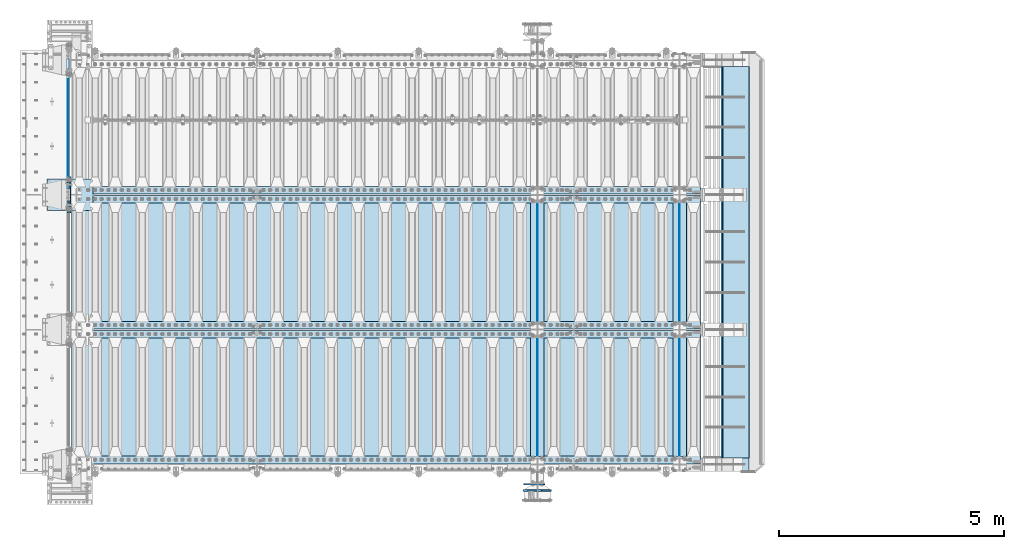
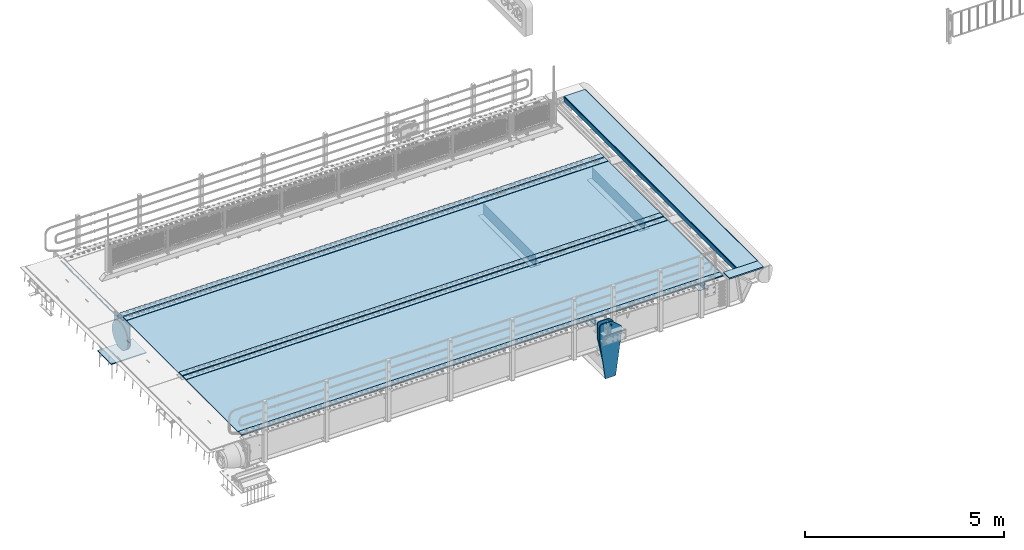
# One storey, part 171 of 219: 24 plates.
"""IFC2X3 building model written with IfcOpenShell, lengths in millimetres."""

from ifc_helpers import new_model, si_unit, frame, origin_with_axes, place, context, subcontext, project, spatial, faceted_brep, material, type_object, element, save


model = new_model("IFC2X3")

# Units and contexts
model_context = context("Model", 3, precision=1e-05, world=origin_with_axes())
body_context = subcontext(model_context, "Body", "Model", "MODEL_VIEW")
ifc_project = project(units=[si_unit("LENGTHUNIT", "METRE", prefix="MILLI"), si_unit("AREAUNIT", "SQUARE_METRE"), si_unit("VOLUMEUNIT", "CUBIC_METRE"), si_unit("MASSUNIT", "GRAM", prefix="KILO"), si_unit("TIMEUNIT", "SECOND"), si_unit("PLANEANGLEUNIT", "RADIAN"), si_unit("SOLIDANGLEUNIT", "STERADIAN"), si_unit("THERMODYNAMICTEMPERATUREUNIT", "DEGREE_CELSIUS"), si_unit("LUMINOUSINTENSITYUNIT", "LUMEN")], contexts=[model_context])

# Site, building, storey
site_placement = place(None, origin_with_axes())
site = spatial("IfcSite", under=ifc_project, at=site_placement, CompositionType="ELEMENT")
building_placement = place(site_placement, origin_with_axes())
building = spatial("IfcBuilding", under=site, at=building_placement, Name="Standard", CompositionType="ELEMENT")
storey_placement = place(building_placement, origin_with_axes())
storey = spatial("IfcBuildingStorey", under=building, at=storey_placement, Name="Undefined", CompositionType="ELEMENT", Elevation=0.0)

# Plates
ifc_material_1 = material(Name="STEEL/S355N")
plate_type_1 = type_object("IfcPlateType", PredefinedType="NOTDEFINED")
plate_1_placement = place(storey_placement, frame((-57.5, 33002.5000993725, -35.9858217417067), z_axis=(0.0, -0.999999999987744, -4.95099999993769e-06), x_axis=(0.0, 4.95100000930963e-06, -0.999999999987744)))
element("IfcPlate", 1, at=plate_1_placement, inside=storey, type_object=plate_type_1, material=ifc_material_1, context=body_context, shape_type="Brep", body=[
    faceted_brep([(0.0, -7.49999999999999, 0.0), (8.68993765834603e-12, -7.49999999999999, 150.000000000004), (8.68993765834603e-12, 7.5, 150.000000000004), (0.0, 7.5, 0.0), (-14.9999999999986, -7.49999999999999, 150.0), (-14.9999999999986, 7.5, 150.0), (-14.9999999999972, -7.49999999999999, 300.0), (-14.9999999999972, 7.5, 300.0), (1.55395696310734e-11, -7.49999999999999, 300.0), (1.55395696310734e-11, 7.5, 300.0), (1.87725390787818e-11, -7.49999999999999, 450.0), (1.87725390787818e-11, 7.5, 450.0), (-14.9999999999958, -7.49999999999999, 450.0), (-14.9999999999958, 7.5, 450.0), (-14.9999999999944, -7.49999999999999, 600.0), (-14.9999999999944, 7.5, 600.0), (2.74553713097703e-11, -7.49999999999999, 600.000000000004), (2.74553713097703e-11, 7.5, 600.000000000004), (3.24931193063094e-11, -7.49999999999999, 750.0), (3.24931193063094e-11, 7.5, 750.0), (-14.999999999993, -7.49999999999999, 750.0), (-14.999999999993, 7.5, 750.0), (-14.9999999999916, -7.49999999999999, 900.000000000004), (-14.9999999999916, 7.5, 900.000000000004), (4.11830569646554e-11, -7.49999999999999, 900.0), (4.11830569646554e-11, 7.5, 900.0), (4.62208049611945e-11, -7.49999999999999, 1050.0), (4.62208049611945e-11, 7.5, 1050.0), (-14.9999999999902, -7.49999999999999, 1050.0), (-14.9999999999902, 7.5, 1050.0), (-14.9999999999888, -7.49999999999999, 1200.0), (-14.9999999999888, 7.5, 1200.0), (5.30917532159947e-11, -7.49999999999999, 1200.0), (5.30917532159947e-11, 7.5, 1200.0), (5.99484906160797e-11, -7.49999999999999, 1350.0), (5.99484906160797e-11, 7.5, 1350.0), (-14.9999999999873, -7.49999999999999, 1350.0), (-14.9999999999873, 7.5, 1350.0), (-14.9999999999859, -7.49999999999999, 1500.0), (-14.9999999999859, 7.5, 1500.0), (6.49933440399764e-11, -7.49999999999999, 1500.0), (6.49933440399764e-11, 7.5, 1500.0), (7.36761762709648e-11, -7.49999999999999, 1650.0), (7.36761762709648e-11, 7.5, 1650.0), (-14.9999999999845, -7.49999999999999, 1650.0), (-14.9999999999845, 7.5, 1650.0), (-14.9999999999831, -7.49999999999999, 1800.0), (-14.9999999999831, 7.5, 1800.0), (7.6894934863958e-11, -7.49999999999999, 1800.0), (7.6894934863958e-11, 7.5, 1800.0), (8.37587776914006e-11, -7.49999999999999, 1950.0), (8.37587776914006e-11, 7.5, 1950.0), (-14.9999999999817, -7.49999999999999, 1950.0), (-14.9999999999817, 7.5, 1950.0), (-14.9999999999803, -7.49999999999999, 2100.0), (-14.9999999999803, 7.5, 2100.0), (9.06297259462008e-11, -7.49999999999999, 2100.0), (9.06297259462008e-11, 7.5, 2100.0), (9.56674739427399e-11, -7.49999999999999, 2250.0), (9.56674739427399e-11, 7.5, 2250.0), (-14.9999999999789, -7.49999999999999, 2250.0), (-14.9999999999789, 7.5, 2250.0), (-14.9999999999775, -7.49999999999999, 2400.0), (-14.9999999999775, 7.5, 2400.0), (1.04350306173728e-10, -7.49999999999999, 2400.0), (1.04350306173728e-10, 7.5, 2400.0), (1.09388054170267e-10, -7.49999999999999, 2550.0), (1.09388054170267e-10, 7.5, 2550.0), (-14.9999999999761, -7.49999999999999, 2550.0), (-14.9999999999761, 7.5, 2550.0), (-14.9999999999747, -7.49999999999999, 2700.0), (-14.9999999999747, 7.5, 2700.0), (1.14440013021522e-10, -7.49999999999999, 2700.0), (1.14440013021522e-10, 7.5, 2700.0), (1.23115739825153e-10, -7.49999999999999, 2850.0), (1.23115739825153e-10, 7.5, 2850.0), (25.0000000000267, -7.49999999999999, 2850.0), (25.0000000000267, 7.5, 2850.0), (25.0, -7.49999999999999, 0.0), (25.0, 7.5, 0.0)], [[[0, 1, 2, 3]], [[1, 4, 5, 2]], [[4, 6, 7, 5]], [[6, 8, 9, 7]], [[8, 10, 11, 9]], [[10, 12, 13, 11]], [[12, 14, 15, 13]], [[14, 16, 17, 15]], [[16, 18, 19, 17]], [[18, 20, 21, 19]], [[20, 22, 23, 21]], [[22, 24, 25, 23]], [[24, 26, 27, 25]], [[26, 28, 29, 27]], [[28, 30, 31, 29]], [[30, 32, 33, 31]], [[32, 34, 35, 33]], [[34, 36, 37, 35]], [[36, 38, 39, 37]], [[38, 40, 41, 39]], [[40, 42, 43, 41]], [[42, 44, 45, 43]], [[44, 46, 47, 45]], [[46, 48, 49, 47]], [[48, 50, 51, 49]], [[50, 52, 53, 51]], [[52, 54, 55, 53]], [[54, 56, 57, 55]], [[56, 58, 59, 57]], [[58, 60, 61, 59]], [[60, 62, 63, 61]], [[62, 64, 65, 63]], [[64, 66, 67, 65]], [[66, 68, 69, 67]], [[68, 70, 71, 69]], [[70, 72, 73, 71]], [[72, 74, 75, 73]], [[74, 76, 77, 75]], [[76, 78, 79, 77]], [[78, 0, 3, 79]], [[5, 7, 9, 11, 13, 15, 17, 19, 21, 23, 25, 27, 29, 31, 33, 35, 37, 39, 41, 43, 45, 47, 49, 51, 53, 55, 57, 59, 61, 63, 65, 67, 69, 71, 73, 75, 77, 79, 3, 2]], [[78, 76, 74, 72, 70, 68, 66, 64, 62, 60, 58, 56, 54, 52, 50, 48, 46, 44, 42, 40, 38, 36, 34, 32, 30, 28, 26, 24, 22, 20, 18, 16, 14, 12, 10, 8, 6, 4, 1, 0]]]),
])
plate_type_2 = type_object("IfcPlateType", PredefinedType="NOTDEFINED")
for number, where, z_axis, x_axis in (
    (2, (13555.0, 26825.0, 0.0), (0.0, 0.0, -1.0), (0.0, -1.0, 0.0)),
    (3, (13555.0, 29825.0, 0.0), (0.0, 0.0, -1.0), (0.0, -1.0, 0.0)),
    (4, (10390.0, 29825.0, 0.0), (0.0, 0.0, -1.0), (0.0, -1.0, 0.0)),
    (5, (10390.0, 26825.0, 0.0), (0.0, 0.0, -1.0), (0.0, -1.0, 0.0)),
):
    element("IfcPlate", number, at=place(storey_placement, frame(where, z_axis=z_axis, x_axis=x_axis)), inside=storey, type_object=plate_type_2, material=ifc_material_1, context=body_context, shape_type="Brep", body=[
        faceted_brep([(0.0, -5.0, 0.0), (0.0, -5.0, 336.0), (0.0, 5.0, 336.0), (0.0, 5.0, 0.0), (2650.0, -5.0, 336.0), (2650.0, 5.0, 336.0), (2650.0, -5.0, 0.0), (2650.0, 5.0, 0.0)], [[[0, 1, 2, 3]], [[1, 4, 5, 2]], [[4, 6, 7, 5]], [[6, 0, 3, 7]], [[5, 7, 3, 2]], [[6, 4, 1, 0]]]),
    ])
plate_type_3 = type_object("IfcPlateType", PredefinedType="NOTDEFINED")
for number, where, z_axis, x_axis in (
    (6, (13405.0, 24175.0, -343.0), (0.0, 1.0, 0.0), (1.0, 0.0, 0.0)),
    (7, (13405.0, 27175.0, -343.0), (0.0, 1.0, 0.0), (1.0, 0.0, 0.0)),
    (8, (10240.0, 27175.0, -343.0), (0.0, 1.0, 0.0), (1.0, 0.0, 0.0)),
    (9, (10240.0, 24175.0, -343.0), (0.0, 1.0, 0.0), (1.0, 0.0, 0.0)),
):
    element("IfcPlate", number, at=place(storey_placement, frame(where, z_axis=z_axis, x_axis=x_axis)), inside=storey, type_object=plate_type_3, material=ifc_material_1, context=body_context, shape_type="Brep", body=[
        faceted_brep([(0.0, -7.0, 0.0), (0.0, -7.0, 2650.0), (0.0, 7.0, 2650.0), (0.0, 7.0, 0.0), (300.0, -7.0, 2650.0), (300.0, 7.0, 2650.0), (300.0, -7.0, 0.0), (300.0, 7.0, 0.0)], [[[0, 1, 2, 3]], [[1, 4, 5, 2]], [[4, 6, 7, 5]], [[6, 0, 3, 7]], [[5, 7, 3, 2]], [[6, 4, 1, 0]]]),
    ])
plate_type_4 = type_object("IfcPlateType", PredefinedType="NOTDEFINED")
plate_2_placement = place(storey_placement, frame((14106.9988298906, 24150.0, -10.0000000000094), z_axis=(1.0, 0.0, 0.0), x_axis=(0.0, -1.0, 0.0)))
element("IfcPlate", 10, at=plate_2_placement, inside=storey, type_object=plate_type_4, material=ifc_material_1, context=body_context, shape_type="Brep", body=[
    faceted_brep([(300.0, 7.0, 986.0), (300.0, 20.0, 956.0), (-3.63797880709171e-11, 20.0, 956.0), (-3.63797880709171e-11, 7.0, 986.0), (0.0, 20.0, 0.0), (0.0, -20.0, 0.0), (-3.63797880709171e-11, -20.0, 986.0), (300.0, -20.0, 986.0), (300.0, -20.0, -1.81898940354586e-12), (300.0, 20.0, -1.81898940354586e-12)], [[[0, 1, 2, 3]], [[4, 5, 6, 3, 2]], [[6, 7, 0, 3]], [[7, 8, 9, 1, 0]], [[8, 5, 4, 9]], [[9, 4, 2, 1]], [[8, 7, 6, 5]]]),
])
plate_type_5 = type_object("IfcPlateType", PredefinedType="NOTDEFINED")
plate_3_placement = place(storey_placement, frame((-523.999999999996, 30350.0, -1043.0), z_axis=(1.0, 0.0, 0.0), x_axis=(0.0, -1.0, 0.0)))
element("IfcPlate", 11, at=plate_3_placement, inside=storey, type_object=plate_type_5, material=ifc_material_1, context=body_context, shape_type="Brep", body=[
    faceted_brep([(0.0, -15.0, 0.0), (3.03448287013453e-05, -15.0, 1025.0), (3.03448287013453e-05, 15.0, 1025.0), (0.0, 15.0, 0.0), (700.0, -15.0, 1025.0), (700.0, 15.0, 1025.0), (700.0, -15.0, -6.3664629124105e-12), (700.0, 15.0, -6.3664629124105e-12)], [[[0, 1, 2, 3]], [[1, 4, 5, 2]], [[4, 6, 7, 5]], [[6, 0, 3, 7]], [[5, 7, 3, 2]], [[6, 4, 1, 0]]]),
])
ifc_material_2 = material(Name="STEEL/S235JR")
plate_type_6 = type_object("IfcPlateType", PredefinedType="NOTDEFINED")
for number, where, z_axis, x_axis in (
    (12, (14017.0, 30015.0, 20.0), (-1.0, 0.0, 0.0), (0.0, 1.0, 0.0)),
    (13, (14017.0, 29815.0, 20.0), (-1.0, 0.0, 0.0), (0.0, 1.0, 0.0)),
    (14, (14017.0, 27015.0, 20.0), (-1.0, 0.0, 0.0), (0.0, 1.0, 0.0)),
    (15, (14017.0, 26815.0, 20.0), (-1.0, 0.0, 0.0), (0.0, 1.0, 0.0)),
    (16, (14017.0, 24015.0, 20.0), (-1.0, 0.0, 0.0), (0.0, 1.0, 0.0)),
):
    element("IfcPlate", number, at=place(storey_placement, frame(where, z_axis=z_axis, x_axis=x_axis)), inside=storey, type_object=plate_type_6, material=ifc_material_2, context=body_context, shape_type="Brep", body=[
        faceted_brep([(0.0, -6.0, 0.0), (0.0, -6.0, 13997.0), (0.0, 6.0, 13997.0), (0.0, 6.0, 0.0), (170.0, -6.0, 13997.0), (170.0, 6.0, 13997.0), (170.0, -6.0, 0.0), (170.0, 6.0, 0.0)], [[[0, 1, 2, 3]], [[1, 4, 5, 2]], [[4, 6, 7, 5]], [[6, 0, 3, 7]], [[5, 7, 3, 2]], [[6, 4, 1, 0]]]),
    ])
plate_type_7 = type_object("IfcPlateType", PredefinedType="NOTDEFINED")
for number, where, z_axis, x_axis in (
    (17, (10.0, 29995.0, 7.0), (1.0, 0.0, 0.0), (0.0, -1.0, 0.0)),
    (18, (10.0, 26995.0, 7.0), (1.0, 0.0, 0.0), (0.0, -1.0, 0.0)),
):
    element("IfcPlate", number, at=place(storey_placement, frame(where, z_axis=z_axis, x_axis=x_axis)), inside=storey, type_object=plate_type_7, material=ifc_material_1, context=body_context, shape_type="Brep", body=[
        faceted_brep([(0.0, -7.0, 0.0), (-2.96859070658684e-09, -7.0, 14017.0), (-2.96859070658684e-09, 7.0, 14017.0), (0.0, 7.0, 0.0), (2990.0, -7.0, 14017.0), (2990.0, 7.0, 14017.0), (2990.0, -7.0, 0.0), (2990.0, 7.0, 0.0)], [[[0, 1, 2, 3]], [[1, 4, 5, 2]], [[4, 6, 7, 5]], [[6, 0, 3, 7]], [[5, 7, 3, 2]], [[6, 4, 1, 0]]]),
    ])
plate_type_8 = type_object("IfcPlateType", PredefinedType="NOTDEFINED")
plate_4_placement = place(storey_placement, frame((-62.5000000000001, 30400.0, -114.999999999998), z_axis=(0.0, 0.0, -1.0), x_axis=(0.0, -1.0, 0.0)))
element("IfcPlate", 19, at=plate_4_placement, inside=storey, type_object=plate_type_8, material=ifc_material_1, context=body_context, shape_type="Brep", body=[
    faceted_brep([(0.0, -12.5, 400.0), (2.91645036198315, -12.5, 448.214672101512), (2.91645036198315, 12.5, 448.214672101512), (0.0, 12.5, 400.0), (11.6232730309421, -12.5, 495.72626571426), (11.6232730309421, 12.5, 495.72626571426), (25.9935029273329, -12.5, 541.8419548161), (25.9935029273329, 12.5, 541.8419548161), (45.8175897403271, -12.5, 585.889268816449), (45.8175897403271, 12.5, 585.889268816449), (70.8064536442325, -12.5, 627.225898691271), (70.8064536442325, 12.5, 627.225898691271), (100.595700733313, -12.5, 665.249063294999), (100.595700733313, 12.5, 665.249063294999), (134.750936705474, -12.5, 699.404299267018), (134.750936705474, 12.5, 699.404299267018), (172.774101309333, -12.5, 729.193546355957), (172.774101309333, 12.5, 729.193546355957), (214.110731184279, -12.5, 754.182410259709), (214.110731184279, 12.5, 754.182410259709), (258.15804518474, -12.5, 774.006497072558), (258.15804518474, 12.5, 774.006497072558), (304.273734286682, -12.5, 788.376726968803), (304.273734286682, 12.5, 788.376726968803), (351.785327899517, -12.5, 797.08354963762), (351.785327899517, 12.5, 797.08354963762), (400.0, -12.5, 800.0), (400.0, 12.5, 800.0), (448.21467210335, -12.5, 797.083549637642), (448.21467210335, 12.5, 797.083549637642), (495.726265715995, -12.5, 788.37672696916), (495.726265715995, 12.5, 788.37672696916), (541.841954817748, -12.5, 774.006497073235), (541.841954817748, 12.5, 774.006497073235), (585.889268818006, -12.5, 754.182410260695), (585.889268818006, 12.5, 754.182410260695), (627.225898692734, -12.5, 729.193546357212), (627.225898692734, 12.5, 729.193546357212), (665.249063296356, -12.5, 699.404299268539), (665.249063296356, 12.5, 699.404299268539), (699.404299268259, -12.5, 665.24906329676), (699.404299268259, 12.5, 665.24906329676), (729.193546357063, -12.5, 627.22589869325), (729.193546357063, 12.5, 627.22589869325), (754.18241026067, -12.5, 585.889268818639), (754.18241026067, 12.5, 585.889268818639), (774.006497073347, -12.5, 541.841954818479), (774.006497073347, 12.5, 541.841954818479), (788.376726969396, -12.5, 495.726265716821), (788.376726969396, 12.5, 495.726265716821), (797.083549638002, -12.5, 448.214672104252), (797.083549638002, 12.5, 448.214672104252), (800.0, -12.5, 400.0), (800.0, 12.5, 400.0), (797.083549639287, -12.5, 351.785327898364), (797.083549639287, 12.5, 351.785327898364), (788.376726970528, -12.5, 304.273734285453), (788.376726970528, 12.5, 304.273734285453), (774.006497074311, -12.5, 258.158045183416), (774.006497074311, 12.5, 258.158045183416), (754.182410261463, -12.5, 214.110731182853), (754.182410261463, 12.5, 214.110731182853), (729.193546357659, -12.5, 172.774101307812), (729.193546357659, 12.5, 172.774101307812), (699.404299268663, -12.5, 134.750936703855), (699.404299268663, 12.5, 134.750936703855), (665.24906329656, -12.5, 100.595700731628), (665.24906329656, 12.5, 100.595700731628), (627.225898692719, -12.5, 70.8064536425045), (627.225898692719, 12.5, 70.8064536425045), (585.889268817788, -12.5, 45.8175897385809), (585.889268817788, 12.5, 45.8175897385809), (541.841954817326, -12.5, 25.9935029256012), (541.841954817326, 12.5, 25.9935029256012), (495.726265715377, -12.5, 11.6232730292504), (495.726265715377, 12.5, 11.6232730292504), (448.214672102542, -12.5, 2.91645036037517), (448.214672102542, 12.5, 2.91645036037517), (400.0, -12.5, -5.6843418860808e-14), (400.0, 12.5, -5.6843418860808e-14), (351.785327896665, -12.5, 2.91645036236514), (351.785327896665, 12.5, 2.91645036236514), (304.273734284012, -12.5, 11.6232730308511), (304.273734284012, 12.5, 11.6232730308511), (258.158045182267, -12.5, 25.9935029267763), (258.158045182267, 12.5, 25.9935029267763), (214.110731182009, -12.5, 45.8175897393157), (214.110731182009, 12.5, 45.8175897393157), (172.774101307281, -12.5, 70.8064536427992), (172.774101307281, 12.5, 70.8064536427992), (134.750936703655, -12.5, 100.595700731472), (134.750936703655, 12.5, 100.595700731472), (100.595700731748, -12.5, 134.750936703247), (100.595700731748, 12.5, 134.750936703247), (70.8064536429447, -12.5, 172.774101306761), (70.8064536429447, 12.5, 172.774101306761), (45.8175897393376, -12.5, 214.110731181379), (45.8175897393376, 12.5, 214.110731181379), (25.9935029266635, -12.5, 258.158045181532), (25.9935029266635, 12.5, 258.158045181532), (11.6232730306074, -12.5, 304.273734283186), (11.6232730306074, 12.5, 304.273734283186), (2.9164503619977, -12.5, 351.785327895759), (2.9164503619977, 12.5, 351.785327895759)], [[[0, 1, 2, 3]], [[1, 4, 5, 2]], [[4, 6, 7, 5]], [[6, 8, 9, 7]], [[8, 10, 11, 9]], [[10, 12, 13, 11]], [[12, 14, 15, 13]], [[14, 16, 17, 15]], [[16, 18, 19, 17]], [[18, 20, 21, 19]], [[20, 22, 23, 21]], [[22, 24, 25, 23]], [[24, 26, 27, 25]], [[26, 28, 29, 27]], [[28, 30, 31, 29]], [[30, 32, 33, 31]], [[32, 34, 35, 33]], [[34, 36, 37, 35]], [[36, 38, 39, 37]], [[38, 40, 41, 39]], [[40, 42, 43, 41]], [[42, 44, 45, 43]], [[44, 46, 47, 45]], [[46, 48, 49, 47]], [[48, 50, 51, 49]], [[50, 52, 53, 51]], [[52, 54, 55, 53]], [[54, 56, 57, 55]], [[56, 58, 59, 57]], [[58, 60, 61, 59]], [[60, 62, 63, 61]], [[62, 64, 65, 63]], [[64, 66, 67, 65]], [[66, 68, 69, 67]], [[68, 70, 71, 69]], [[70, 72, 73, 71]], [[72, 74, 75, 73]], [[74, 76, 77, 75]], [[76, 78, 79, 77]], [[78, 80, 81, 79]], [[80, 82, 83, 81]], [[82, 84, 85, 83]], [[84, 86, 87, 85]], [[86, 88, 89, 87]], [[88, 90, 91, 89]], [[90, 92, 93, 91]], [[92, 94, 95, 93]], [[94, 96, 97, 95]], [[96, 98, 99, 97]], [[98, 100, 101, 99]], [[100, 102, 103, 101]], [[102, 0, 3, 103]], [[5, 7, 9, 11, 13, 15, 17, 19, 21, 23, 25, 27, 29, 31, 33, 35, 37, 39, 41, 43, 45, 47, 49, 51, 53, 55, 57, 59, 61, 63, 65, 67, 69, 71, 73, 75, 77, 79, 81, 83, 85, 87, 89, 91, 93, 95, 97, 99, 101, 103, 3, 2]], [[102, 100, 98, 96, 94, 92, 90, 88, 86, 84, 82, 80, 78, 76, 74, 72, 70, 68, 66, 64, 62, 60, 58, 56, 54, 52, 50, 48, 46, 44, 42, 40, 38, 36, 34, 32, 30, 28, 26, 24, 22, 20, 18, 16, 14, 12, 10, 8, 6, 4, 1, 0]]]),
])
plate_type_9 = type_object("IfcPlateType", PredefinedType="NOTDEFINED")
plate_5_placement = place(storey_placement, frame((-5.0, 29600.0, -20.0), z_axis=(0.0, 1.0, 0.0), x_axis=(0.0, 0.0, -1.0)))
element("IfcPlate", 20, at=plate_5_placement, inside=storey, type_object=plate_type_9, material=ifc_material_1, context=body_context, shape_type="Brep", body=[
    faceted_brep([(855.0, -15.0, 572.963114670027), (855.0, 15.0, 572.963114670027), (849.182410260917, 15.0, 585.889268816907), (849.182410260917, -15.0, 585.889268816907), (824.193546357179, 15.0, 627.225898691897), (824.193546357179, -15.0, 627.225898691897), (794.404299268237, 15.0, 665.249063295792), (794.404299268237, -15.0, 665.249063295792), (760.249063296204, 15.0, 699.404299267975), (760.249063296204, -15.0, 699.404299267975), (722.225898692443, 15.0, 729.193546357055), (722.225898692443, -15.0, 729.193546357055), (680.889268817573, 15.0, 754.182410260939), (680.889268817573, -15.0, 754.182410260939), (636.841954817181, 15.0, 774.006497073904), (636.841954817181, -15.0, 774.006497073904), (590.726265715286, 15.0, 788.376726970237), (590.726265715286, -15.0, 788.376726970237), (543.214672102495, 15.0, 797.083549639108), (543.214672102495, -15.0, 797.083549639108), (495.0, -15.0, 800.000000000029), (495.0, 15.0, 800.0), (494.999999999412, -15.0, 0.0), (494.999999999412, 15.0, 0.0), (543.214672105067, 15.0, 2.91645036483533), (543.214672105067, -15.0, 2.91645036483533), (590.726265717545, 15.0, 11.623273033314), (590.726265717545, -15.0, 11.623273033314), (636.841954819123, 15.0, 25.9935029292174), (636.841954819123, -15.0, 25.9935029292174), (680.889268819221, 15.0, 45.8175897417386), (680.889268819221, -15.0, 45.8175897417386), (722.225898693796, 15.0, 70.8064536451857), (722.225898693796, -15.0, 70.8064536451857), (760.249063297284, 15.0, 100.595700733822), (760.249063297284, -15.0, 100.595700733822), (794.404299269056, 15.0, 134.750936705557), (794.404299269056, -15.0, 134.750936705557), (824.193546357754, 15.0, 172.77410130902), (824.193546357754, -15.0, 172.77410130902), (849.182410261274, 15.0, 214.110731183588), (849.182410261274, -15.0, 214.110731183588), (855.0, -15.0, 227.03688532969), (855.0, 15.0, 227.03688532969), (0.0, -15.0, 0.0), (0.0, 15.0, 0.0), (0.0, 15.0, 800.0), (0.0, -15.0, 800.0)], [[[0, 1, 2, 3]], [[3, 2, 4, 5]], [[5, 4, 6, 7]], [[7, 6, 8, 9]], [[9, 8, 10, 11]], [[11, 10, 12, 13]], [[13, 12, 14, 15]], [[15, 14, 16, 17]], [[17, 16, 18, 19]], [[20, 19, 18, 21]], [[22, 23, 24, 25]], [[25, 24, 26, 27]], [[27, 26, 28, 29]], [[29, 28, 30, 31]], [[31, 30, 32, 33]], [[33, 32, 34, 35]], [[35, 34, 36, 37]], [[37, 36, 38, 39]], [[39, 38, 40, 41]], [[42, 41, 40, 43]], [[42, 43, 1, 0]], [[44, 45, 23, 22]], [[16, 14, 12, 10, 8, 6, 4, 2, 1, 43, 40, 38, 36, 34, 32, 30, 28, 26, 24, 23, 45, 46, 21, 18]], [[44, 47, 46, 45]], [[46, 47, 20, 21]], [[47, 44, 22, 25, 27, 29, 31, 33, 35, 37, 39, 41, 42, 0, 3, 5, 7, 9, 11, 13, 15, 17, 19, 20]]]),
])
plate_type_10 = type_object("IfcPlateType", PredefinedType="NOTDEFINED")
plate_6_placement = place(storey_placement, frame((10550.0000000349, 23560.0000000149, -945.00001821268), z_axis=(-0.901283188008788, 0.0, 0.433230441004225), x_axis=(-0.433230441004226, 0.0, -0.901283188008788)))
element("IfcPlate", 21, at=plate_6_placement, inside=storey, type_object=plate_type_10, material=ifc_material_1, context=body_context, shape_type="Brep", body=[
    faceted_brep([(22.0942403584436, -15.0000000000073, 175.225838726672), (22.0942403584436, 14.9999999999927, 175.225838726672), (270.848403405487, 15.0, 55.6542354921748), (270.848403405487, -15.0, 55.6542354921748), (15.5957837433803, -15.0000000000073, 161.70659090654), (15.5957837433803, 14.9999999999927, 161.70659090654), (264.349945992725, -15.0, 42.1349880554844), (264.349945992725, 15.0, 42.1349880554844), (244.096420288085, -15.0, -9.27684595808387e-11), (244.096420288085, 15.0, -9.27684595808387e-11), (0.0, -15.0, 0.0), (0.0, 15.0, 0.0), (-976.801818847658, -15.0, 469.530853271484), (-976.801818847658, 15.0, 469.530853271484), (-1005.61098604242, -15.0, 584.57248126679), (-1005.61098604242, 15.0, 584.57248126679), (-1008.62084772112, -15.0, 603.379189822304), (-1008.62084772112, 15.0, 603.379189822303), (-1008.34151554697, -14.9999999999964, 622.423179098552), (-1008.34151554697, 15.0000000000036, 622.423179098552), (-1004.7813898293, -15.0, 641.133500175491), (-1004.7813898293, 15.0, 641.133500175491), (-998.047132923921, -15.0, 658.949304871176), (-998.047132923921, 15.0, 658.949304871176), (-903.393050005924, -15.0, 855.86569143182), (-903.393050005924, 15.0, 855.86569143182), (-891.965949445596, -15.0, 873.346281101727), (-891.965949445597, 15.0, 873.346281101727), (-876.403907448142, -15.0, 887.273681838966), (-876.403907448142, 15.0, 887.273681838964), (-857.767451990592, -15.0, 896.698763822953), (-857.767451990592, 15.0, 896.698763822953), (-837.326627351689, -14.9999999999964, 900.979222969758), (-837.32662735169, 15.0000000000036, 900.979222969756), (-816.474442649739, -15.0, 899.823352915892), (-816.474442649738, 15.0, 899.823352915893), (-796.631940525472, -14.9999999999964, 893.309924335021), (-796.631940525473, 15.0000000000036, 893.309924335019), (-427.105804443362, -14.9999999999964, 715.685363769533), (-427.105804443361, 15.0000000000036, 715.685363769531), (138.633743286132, -15.0, 288.410614013672), (138.633743286132, 15.0, 288.410614013672), (291.101928710937, -15.0, 97.7892227172852), (291.101928710937, 15.0, 97.7892227172852), (-886.324025694375, -15.0000000000146, 572.18228869451), (-886.324025694375, 14.9999999999854, 572.18228869451), (-901.776420284152, 14.9999999999854, 569.989346058295), (-901.776420284152, -15.0000000000146, 569.989346058295), (-872.8870774196, -15.0000000000146, 580.121678911957), (-872.8870774196, 14.9999999999854, 580.121678911957), (-863.511229028421, -15.0000000000146, 592.59881652078), (-863.511229028421, 14.9999999999854, 592.59881652078), (-859.623868446117, -15.0000000000146, 607.71417042557), (-859.623868446117, 14.9999999999854, 607.71417042557), (-861.816811082334, -15.0000000000146, 623.166565015345), (-861.816811082334, 14.9999999999854, 623.166565015345), (-869.756201299781, -15.0000000000146, 636.603513290122), (-869.756201299781, 14.9999999999854, 636.603513290122), (-882.233338908602, -15.0000000000146, 645.9793616813), (-882.233338908602, 14.9999999999854, 645.9793616813), (-897.348692813393, -15.0000000000146, 649.866722263603), (-897.348692813393, 14.9999999999854, 649.866722263603), (-912.801087403169, -15.0000000000146, 647.673779627386), (-912.801087403169, 14.9999999999854, 647.673779627386), (-926.238035677944, -15.0000000000146, 639.734389409941), (-926.238035677944, 14.9999999999854, 639.734389409941), (-935.613884069124, -15.0000000000146, 627.257251801118), (-935.613884069124, 14.9999999999854, 627.257251801118), (-939.501244651427, -15.0000000000146, 612.141897896328), (-939.501244651427, 14.9999999999854, 612.141897896328), (-937.308302015211, -15.0000000000146, 596.689503306552), (-937.308302015211, 14.9999999999854, 596.689503306552), (-929.368911797764, -15.0000000000146, 583.252555031777), (-929.368911797764, 14.9999999999854, 583.252555031777), (-916.891774188941, -15.0000000000146, 573.876706640596), (-916.891774188941, 14.9999999999854, 573.876706640596), (-844.133640463935, 15.0, 583.284362063439), (-843.858297547697, 15.0, 588.251621193805), (-847.175983319465, 15.0, 591.958700652023), (-852.143242449833, 15.0, 592.234043568264), (-855.850321908049, 15.0, 588.916357796496), (-856.125664824289, 15.0, 583.949098666128), (-852.80797905252, 15.0, 580.24201920791), (-847.840719922153, 15.0, 579.96667629167), (-847.840719922153, -15.0, 579.96667629167), (-852.80797905252, -15.0, 580.24201920791), (-844.133640463935, -15.0, 583.284362063439), (-843.858297547697, -15.0, 588.251621193805), (-847.175983319465, -15.0, 591.958700652023), (-852.143242449833, -15.0, 592.234043568264), (-855.850321908049, -15.0, 588.916357796496), (-856.125664824289, -15.0, 583.949098666128)], [[[0, 1, 2, 3]], [[4, 5, 1, 0]], [[6, 7, 5, 4]], [[8, 9, 7, 6]], [[8, 10, 11, 9]], [[10, 12, 13, 11]], [[12, 14, 15, 13]], [[14, 16, 17, 15]], [[16, 18, 19, 17]], [[18, 20, 21, 19]], [[20, 22, 23, 21]], [[22, 24, 25, 23]], [[24, 26, 27, 25]], [[26, 28, 29, 27]], [[28, 30, 31, 29]], [[30, 32, 33, 31]], [[32, 34, 35, 33]], [[34, 36, 37, 35]], [[36, 38, 39, 37]], [[38, 40, 41, 39]], [[40, 42, 43, 41]], [[43, 42, 3, 2]], [[44, 45, 46, 47]], [[48, 49, 45, 44]], [[50, 51, 49, 48]], [[52, 53, 51, 50]], [[54, 55, 53, 52]], [[56, 57, 55, 54]], [[58, 59, 57, 56]], [[60, 61, 59, 58]], [[62, 63, 61, 60]], [[64, 65, 63, 62]], [[66, 67, 65, 64]], [[68, 69, 67, 66]], [[70, 71, 69, 68]], [[72, 73, 71, 70]], [[74, 75, 73, 72]], [[47, 46, 75, 74]], [[9, 11, 13, 15, 17, 19, 21, 23, 25, 27, 29, 31, 33, 35, 37, 39, 41, 43, 2, 1, 5, 7], [76, 77, 78, 79, 80, 81, 82, 83], [45, 49, 51, 53, 55, 57, 59, 61, 63, 65, 67, 69, 71, 73, 75, 46]], [[84, 83, 82, 85]], [[86, 76, 83, 84]], [[87, 77, 76, 86]], [[88, 78, 77, 87]], [[89, 79, 78, 88]], [[90, 80, 79, 89]], [[91, 81, 80, 90]], [[85, 82, 81, 91]], [[3, 42, 40, 38, 36, 34, 32, 30, 28, 26, 24, 22, 20, 18, 16, 14, 12, 10, 8, 6, 4, 0], [90, 89, 88, 87, 86, 84, 85, 91], [70, 68, 66, 64, 62, 60, 58, 56, 54, 52, 50, 48, 44, 47, 74, 72]]]),
])
plate_type_11 = type_object("IfcPlateType", PredefinedType="NOTDEFINED")
plate_7_placement = place(storey_placement, frame((10540.0000000214, 23420.0000000149, -1470.0000182062), z_axis=(0.0, 0.0, 1.0), x_axis=(-1.0, 0.0, 0.0)))
element("IfcPlate", 22, at=plate_7_placement, inside=storey, type_object=plate_type_11, material=ifc_material_1, context=body_context, shape_type="Brep", body=[
    faceted_brep([(145.403805922693, -15.0000000000073, 1549.59619407771), (145.403805922693, 14.9999999999927, 1549.59619407771), (150.000000000406, 14.9999999999927, 1551.5), (150.000000000406, -15.0000000000073, 1551.5), (154.596194078118, 14.9999999999927, 1549.59619407771), (154.596194078118, -15.0000000000073, 1549.59619407771), (156.500000000406, 14.9999999999927, 1545.0), (156.500000000406, -15.0000000000073, 1545.0), (154.596194078118, 14.9999999999927, 1540.40380592229), (154.596194078118, -15.0000000000073, 1540.40380592229), (150.000000000406, 14.9999999999927, 1538.5), (150.000000000406, -15.0000000000073, 1538.5), (145.403805922693, 14.9999999999927, 1540.40380592229), (145.403805922693, -15.0000000000073, 1540.40380592229), (143.500000000406, 14.9999999999927, 1545.0), (143.500000000406, -15.0000000000073, 1545.0), (300.0, -15.0, 0.0), (0.0, -15.0, 0.0), (0.0, 15.0, 0.0), (300.0, 15.0, 0.0), (462.5, -15.0, 1210.0), (462.5, 15.0, 1210.0), (462.5, -15.0, 1630.0), (462.5, 15.0, 1630.0), (459.774066103126, -15.0, 1650.7055236082), (459.774066103126, 15.0, 1650.7055236082), (451.782032302755, -15.0, 1670.0), (451.782032302755, 15.0, 1670.0), (439.068542494924, -15.0, 1686.56854249492), (439.068542494924, 15.0, 1686.56854249492), (422.5, -15.0, 1699.28203230276), (422.5, 15.0, 1699.28203230276), (403.205523608201, -15.0, 1707.27406610313), (403.205523608201, 15.0, 1707.27406610313), (382.5, -15.0, 1710.0), (382.5, 15.0, 1710.0), (151.788081037079, -15.0, 1710.0), (151.788081037079, 15.0, 1710.0), (132.694887325031, -15.0, 1708.33028179541), (132.694887325031, 15.0, 1708.33028179541), (114.181334578885, -15.0, 1703.37181734316), (114.181334578885, 15.0, 1703.37181734316), (96.8094667268542, -15.0, 1695.27513824985), (96.8094667268542, 15.0, 1695.27513824985), (81.1066678416755, -15.0, 1684.28604765144), (81.1066678416755, 15.0, 1684.28604765144), (-162.5, -15.0, 1480.0), (-162.5, 15.0, 1480.0), (-162.5, -15.0, 1210.0), (-162.5, 15.0, 1210.0), (121.715728752944, -15.0, 1628.28427124746), (134.692662705802, -15.0, 1636.95518130045), (150.000000000406, -15.0, 1640.0), (165.307337295009, -15.0, 1636.95518130045), (178.284271247867, -15.0, 1628.28427124746), (186.955181300857, -15.0, 1615.3073372946), (190.000000000406, -15.0, 1600.0), (186.955181300857, -15.0, 1584.6926627054), (178.284271247867, -15.0, 1571.71572875254), (165.307337295009, -15.0, 1563.04481869955), (150.000000000406, -15.0, 1560.0), (134.692662705802, -15.0, 1563.04481869955), (121.715728752944, -15.0, 1571.71572875254), (113.044818699955, -15.0, 1584.6926627054), (110.000000000406, -15.0, 1600.0), (113.044818699955, -15.0, 1615.3073372946), (121.715728752944, 14.9999999999527, 1571.71572875254), (113.044818699955, 14.9999999999527, 1584.6926627054), (134.692662705802, 14.9999999999527, 1563.04481869955), (150.000000000406, 14.9999999999527, 1560.0), (165.307337295009, 14.9999999999527, 1563.04481869955), (178.284271247867, 14.9999999999527, 1571.71572875254), (186.955181300857, 14.9999999999527, 1584.6926627054), (190.000000000406, 14.9999999999527, 1600.0), (186.955181300857, 14.9999999999527, 1615.3073372946), (178.284271247867, 14.9999999999527, 1628.28427124746), (165.307337295009, 14.9999999999527, 1636.95518130045), (150.000000000406, 14.9999999999527, 1640.0), (134.692662705802, 14.9999999999527, 1636.95518130045), (121.715728752944, 14.9999999999527, 1628.28427124746), (113.044818699955, 14.9999999999527, 1615.3073372946), (110.000000000406, 14.9999999999527, 1600.0)], [[[0, 1, 2, 3]], [[3, 2, 4, 5]], [[5, 4, 6, 7]], [[7, 6, 8, 9]], [[9, 8, 10, 11]], [[11, 10, 12, 13]], [[13, 12, 14, 15]], [[15, 14, 1, 0]], [[16, 17, 18, 19]], [[20, 16, 19, 21]], [[22, 20, 21, 23]], [[24, 22, 23, 25]], [[26, 24, 25, 27]], [[28, 26, 27, 29]], [[30, 28, 29, 31]], [[32, 30, 31, 33]], [[34, 32, 33, 35]], [[36, 34, 35, 37]], [[38, 36, 37, 39]], [[40, 38, 39, 41]], [[42, 40, 41, 43]], [[44, 42, 43, 45]], [[46, 44, 45, 47]], [[48, 46, 47, 49]], [[17, 48, 49, 18]], [[16, 20, 22, 24, 26, 28, 30, 32, 34, 36, 38, 40, 42, 44, 46, 48, 17], [3, 5, 7, 9, 11, 13, 15, 0], [50, 51, 52, 53, 54, 55, 56, 57, 58, 59, 60, 61, 62, 63, 64, 65]], [[62, 66, 67, 63]], [[61, 68, 66, 62]], [[60, 69, 68, 61]], [[59, 70, 69, 60]], [[58, 71, 70, 59]], [[57, 72, 71, 58]], [[56, 73, 72, 57]], [[55, 74, 73, 56]], [[54, 75, 74, 55]], [[53, 76, 75, 54]], [[52, 77, 76, 53]], [[51, 78, 77, 52]], [[50, 79, 78, 51]], [[65, 80, 79, 50]], [[64, 81, 80, 65]], [[63, 67, 81, 64]], [[47, 45, 43, 41, 39, 37, 35, 33, 31, 29, 27, 25, 23, 21, 19, 18, 49], [10, 8, 6, 4, 2, 1, 14, 12], [66, 68, 69, 70, 71, 72, 73, 74, 75, 76, 77, 78, 79, 80, 81, 67]]]),
])
plate_type_12 = type_object("IfcPlateType", PredefinedType="NOTDEFINED")
plate_8_placement = place(storey_placement, frame((14500.5545510642, 32850.0000000016, -155.274111776634), z_axis=(0.0, -1.0, 0.0), x_axis=(-0.0871556999853862, 0.0, 0.996194701832959)))
element("IfcPlate", 23, at=plate_8_placement, inside=storey, type_object=plate_type_12, material=ifc_material_1, context=body_context, shape_type="Brep", body=[
    faceted_brep([(0.0, -10.0, 0.0), (-4.54747350886464e-13, -10.0, 8700.0), (-4.54747350886464e-13, 10.0, 8700.0), (0.0, 10.0, 0.0), (155.0, -10.0000000000018, 8700.0), (155.0, 10.0, 8700.0), (155.0, -10.0000000000018, 0.0), (155.0, 10.0, 0.0)], [[[0, 1, 2, 3]], [[1, 4, 5, 2]], [[4, 6, 7, 5]], [[6, 0, 3, 7]], [[5, 7, 3, 2]], [[6, 4, 1, 0]]]),
])
plate_type_13 = type_object("IfcPlateType", PredefinedType="NOTDEFINED")
plate_9_placement = place(storey_placement, frame((14497.002968026, 32850.0000000016, 0.00398537333359528), z_axis=(0.999999999980065, 4.24999998350071e-07, -6.29999999987441e-06), x_axis=(0.0, -1.0, 0.0)))
element("IfcPlate", 24, at=plate_9_placement, inside=storey, type_object=plate_type_13, material=ifc_material_1, context=body_context, shape_type="Brep", body=[
    faceted_brep([(8700.0, -10.0, 596.995666503904), (8700.0, 3.61696783635068e-13, 616.995666503906), (6.7273125750944e-05, -9.07468544752987e-14, 616.995788574221), (6.50924557703547e-05, -10.0, 596.995788574219), (6.7273125750944e-05, 10.0, 616.995788574219), (0.0, 10.0, 0.0), (0.0, -10.0, 0.0), (8700.0, 10.0, 616.995666503906), (8700.0, -10.0, 2.17551132664084e-09), (8700.0, 10.0, 2.17551132664084e-09)], [[[0, 1, 2, 3]], [[4, 5, 6, 3, 2]], [[7, 4, 2, 1]], [[8, 9, 7, 1, 0]], [[8, 6, 5, 9]], [[7, 9, 5, 4]], [[6, 8, 0, 3]]]),
])

save(model, "model.ifc")
